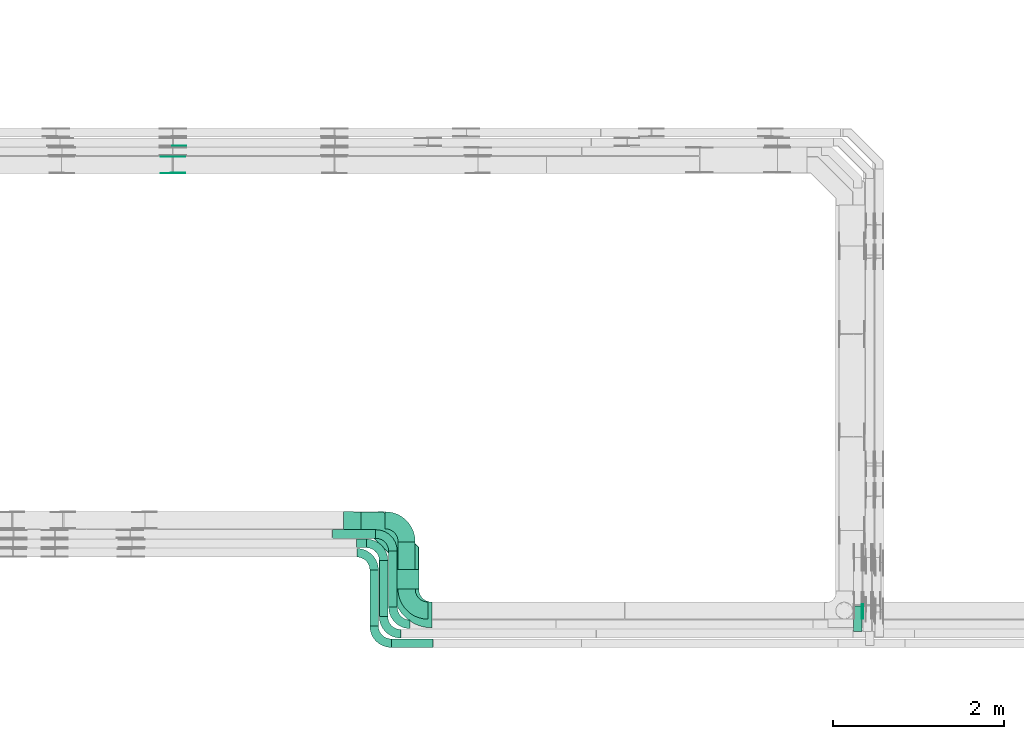
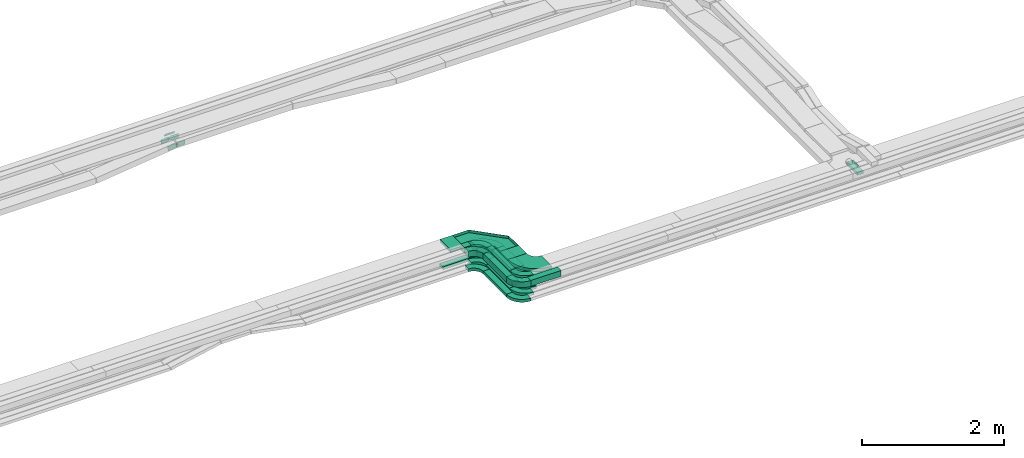
# One storey, part 22 of 32: 21 flow fittings, 12 flow segments.
"""IFC2X3 building model written with IfcOpenShell, lengths in millimetres."""

from ifc_helpers import new_model, entity, si_unit, converted_unit, derived_unit, direction, frame, frame_2d, origin, origin_2d_with_axis, place, context, subcontext, project, spatial, polyline, circle_curve, parameter, trimmed, segment, composite_curve, rectangle, outline, extrude, faceted_brep, source, transform, mapped, material, type_object, type_shapes, element, save


model = new_model("IFC2X3")

# Units and contexts
model_context = context("Model", 3, precision=0.01, world=origin(), true_north=direction((6.12303176911189e-17, 1.0)))
body_context = subcontext(model_context, "Body", "Model", "MODEL_VIEW")
ifc_project = project(units=[si_unit("LENGTHUNIT", "METRE", prefix="MILLI"), si_unit("AREAUNIT", "SQUARE_METRE"), si_unit("VOLUMEUNIT", "CUBIC_METRE"), converted_unit("PLANEANGLEUNIT", "DEGREE", entity("IfcRatioMeasure", 0.0174532925199433), si_unit("PLANEANGLEUNIT", "RADIAN"), dimensions=[0, 0, 0, 0, 0, 0, 0]), si_unit("MASSUNIT", "GRAM", prefix="KILO"), derived_unit("MASSDENSITYUNIT", [(si_unit("MASSUNIT", "GRAM", prefix="KILO"), 1), (si_unit("LENGTHUNIT", "METRE"), -3)]), derived_unit("MOMENTOFINERTIAUNIT", [(si_unit("LENGTHUNIT", "METRE"), 4)]), si_unit("TIMEUNIT", "SECOND"), si_unit("FREQUENCYUNIT", "HERTZ"), si_unit("THERMODYNAMICTEMPERATUREUNIT", "DEGREE_CELSIUS"), derived_unit("THERMALTRANSMITTANCEUNIT", [(si_unit("MASSUNIT", "GRAM", prefix="KILO"), 1), (si_unit("THERMODYNAMICTEMPERATUREUNIT", "KELVIN"), -1), (si_unit("TIMEUNIT", "SECOND"), -3)]), derived_unit("VOLUMETRICFLOWRATEUNIT", [(si_unit("LENGTHUNIT", "METRE"), 3), (si_unit("TIMEUNIT", "SECOND"), -1)]), derived_unit("MASSFLOWRATEUNIT", [(si_unit("MASSUNIT", "GRAM", prefix="KILO"), 1), (si_unit("TIMEUNIT", "SECOND"), -1)]), derived_unit("ROTATIONALFREQUENCYUNIT", [(si_unit("TIMEUNIT", "SECOND"), -1)]), si_unit("ELECTRICCURRENTUNIT", "AMPERE"), si_unit("ELECTRICVOLTAGEUNIT", "VOLT"), si_unit("POWERUNIT", "WATT"), si_unit("FORCEUNIT", "NEWTON", prefix="KILO"), si_unit("ILLUMINANCEUNIT", "LUX"), si_unit("LUMINOUSFLUXUNIT", "LUMEN"), si_unit("LUMINOUSINTENSITYUNIT", "CANDELA"), derived_unit("USERDEFINED", [(si_unit("MASSUNIT", "GRAM", prefix="KILO"), -1), (si_unit("LENGTHUNIT", "METRE"), -2), (si_unit("TIMEUNIT", "SECOND"), 3), (si_unit("LUMINOUSFLUXUNIT", "LUMEN"), 1)]), derived_unit("LINEARVELOCITYUNIT", [(si_unit("LENGTHUNIT", "METRE"), 1), (si_unit("TIMEUNIT", "SECOND"), -1)]), si_unit("PRESSUREUNIT", "PASCAL"), derived_unit("USERDEFINED", [(si_unit("LENGTHUNIT", "METRE"), -2), (si_unit("MASSUNIT", "GRAM", prefix="KILO"), 1), (si_unit("TIMEUNIT", "SECOND"), -2)]), derived_unit("LINEARFORCEUNIT", [(si_unit("MASSUNIT", "GRAM", prefix="KILO"), 1), (si_unit("LENGTHUNIT", "METRE"), 1), (si_unit("TIMEUNIT", "SECOND"), -2), (si_unit("LENGTHUNIT", "METRE"), -1)]), derived_unit("PLANARFORCEUNIT", [(si_unit("MASSUNIT", "GRAM", prefix="KILO"), 1), (si_unit("LENGTHUNIT", "METRE"), 1), (si_unit("TIMEUNIT", "SECOND"), -2), (si_unit("LENGTHUNIT", "METRE"), -2)])], contexts=[model_context])

# Site, building, storey
site_placement = place(None, origin())
site = spatial("IfcSite", under=ifc_project, at=site_placement, CompositionType="ELEMENT")
building_placement = place(site_placement, origin())
building = spatial("IfcBuilding", under=site, at=building_placement, CompositionType="ELEMENT")
storey_placement = place(building_placement, frame((0.0, 0.0, 8100.0)))
storey = spatial("IfcBuildingStorey", under=building, at=storey_placement, CompositionType="ELEMENT", Elevation=8100.0)

# Flow segments
cable_carrier_segment_type = type_object("IfcCableCarrierSegmentType", PredefinedType="CABLETRAYSEGMENT")
flow_segment_1_placement = place(storey_placement, frame((55150.11, 9320.98, 2549.84)))
element("IfcFlowSegment", 1, at=flow_segment_1_placement, inside=storey, type_object=cable_carrier_segment_type, context=body_context, shape_type="SweptSolid", body=[
    extrude(rectangle(XDim=553.020769727205, YDim=200.000000000007, at=origin_2d_with_axis()), frame((100.0, 276.51, 0.0), z_axis=(0.0, 0.0, 1.0), x_axis=(0.0, 1.0, 0.0)), (0.0, 0.0, 1.0), 99.9999999999989),
])
flow_segment_2_placement = place(storey_placement, frame((55040.11, 9110.98, 2549.87)))
element("IfcFlowSegment", 2, at=flow_segment_2_placement, inside=storey, type_object=cable_carrier_segment_type, context=body_context, shape_type="SweptSolid", body=[
    extrude(rectangle(XDim=653.020769727202, YDim=99.9999999999946, at=origin_2d_with_axis()), frame((50.0, 326.51, 0.0), z_axis=(0.0, 0.0, 1.0), x_axis=(0.0, 1.0, 0.0)), (0.0, 0.0, 1.0), 50.0000000000016),
])
flow_segment_3_placement = place(storey_placement, frame((54930.11, 9000.98, 2549.87)))
element("IfcFlowSegment", 3, at=flow_segment_3_placement, inside=storey, type_object=cable_carrier_segment_type, context=body_context, shape_type="SweptSolid", body=[
    extrude(rectangle(XDim=653.020769727214, YDim=99.9999999999946, at=origin_2d_with_axis()), frame((50.0, 326.51, 0.0), z_axis=(0.0, 0.0, 1.0), x_axis=(0.0, 1.0, 0.0)), (0.0, 0.0, 1.0), 50.0000000000016),
])
flow_segment_4_placement = place(storey_placement, frame((54820.11, 8890.98, 2548.16)))
element("IfcFlowSegment", 4, at=flow_segment_4_placement, inside=storey, type_object=cable_carrier_segment_type, context=body_context, shape_type="SweptSolid", body=[
    extrude(rectangle(XDim=653.019323064651, YDim=99.9999999999946, at=origin_2d_with_axis()), frame((50.0, 326.51, 0.0), z_axis=(0.0, 0.0, 1.0), x_axis=(0.0, 1.0, 0.0)), (0.0, 0.0, 1.0), 50.0000000000016),
])
flow_segment_5_placement = place(storey_placement, frame((55092.34, 9320.54, 2789.1)))
element("IfcFlowSegment", 5, at=flow_segment_5_placement, inside=storey, type_object=cable_carrier_segment_type, context=body_context, shape_type="SweptSolid", body=[
    extrude(rectangle(XDim=228.305561513048, YDim=299.999999999992, at=origin_2d_with_axis()), frame((150.11, 114.33, 0.07), z_axis=(5.78252488002628e-07, -0.0006102790268846, 0.99999981377957), x_axis=(-0.000947520880238993, 0.999999364881477, 0.000610279300837866)), (0.0, 0.0, 1.0), 50.0000000000009),
])
flow_segment_6_placement = place(storey_placement, frame((54930.33, 9000.97, 2799.84)))
element("IfcFlowSegment", 6, at=flow_segment_6_placement, inside=storey, type_object=cable_carrier_segment_type, context=body_context, shape_type="SweptSolid", body=[
    extrude(rectangle(XDim=653.020791015254, YDim=99.9999999999946, at=origin_2d_with_axis()), frame((50.0, 326.51, 0.07), z_axis=(0.0, 0.000204778842239003, 0.999999979032813), x_axis=(0.0, -0.999999979032813, 0.000204778842239003)), (0.0, 0.0, 1.0), 100.000000000001),
])
flow_segment_7_placement = place(storey_placement, frame((54820.11, 8890.97, 2799.32)))
element("IfcFlowSegment", 7, at=flow_segment_7_placement, inside=storey, type_object=cable_carrier_segment_type, context=body_context, shape_type="SweptSolid", body=[
    extrude(rectangle(XDim=653.022106435861, YDim=99.999999999999, at=origin_2d_with_axis()), frame((50.0, 326.51, 0.07), z_axis=(8.83740140805357e-07, 0.000204835246373141, 0.99999997902087), x_axis=(0.0, -0.999999979021261, 0.000204835246373221)), (0.0, 0.0, 1.0), 99.9999999999998),
])
flow_segment_8_placement = place(storey_placement, frame((55071.11, 8639.98, 2799.49)))
element("IfcFlowSegment", 8, at=flow_segment_8_placement, inside=storey, type_object=cable_carrier_segment_type, context=body_context, shape_type="SweptSolid", body=[
    extrude(rectangle(XDim=489.621580336119, YDim=99.9999999999995, at=origin_2d_with_axis()), frame((244.81, 50.0, 0.0), z_axis=(3.16498725628962e-07, -2.43771475119288e-05, 1.0), x_axis=(-1.0, 0.0, 3.16498724808628e-07)), (0.0, 0.0, 1.0), 99.999999999998),
])
flow_segment_9_placement = place(storey_placement, frame((54382.06, 9915.0, 2549.87)))
element("IfcFlowSegment", 9, at=flow_segment_9_placement, inside=storey, type_object=cable_carrier_segment_type, context=body_context, shape_type="SweptSolid", body=[
    extrude(rectangle(XDim=507.047725147146, YDim=99.9999999999989, at=origin_2d_with_axis()), frame((253.52, 50.0, 0.0)), (0.0, 0.0, 1.0), 50.0000000000016),
])
flow_segment_10_placement = place(storey_placement, frame((54664.86, 9805.0, 2799.81)))
element("IfcFlowSegment", 10, at=flow_segment_10_placement, inside=storey, type_object=cable_carrier_segment_type, context=body_context, shape_type="SweptSolid", body=[
    extrude(rectangle(XDim=114.4721271414, YDim=99.9999999999989, at=origin_2d_with_axis()), frame((57.24, 50.0, 0.0)), (0.0, 0.0, 1.0), 99.9999999999998),
])
flow_segment_11_placement = place(storey_placement, frame((60470.11, 8826.03, 2697.68)))
element("IfcFlowSegment", 11, at=flow_segment_11_placement, inside=storey, type_object=cable_carrier_segment_type, context=body_context, shape_type="SweptSolid", body=[
    extrude(rectangle(XDim=300.444409805727, YDim=99.9999999999946, at=origin_2d_with_axis()), frame((50.0, 150.22, 0.0), z_axis=(0.0, 0.0, 1.0), x_axis=(0.0, -1.0, 0.0)), (0.0, 0.0, 1.0), 50.0000000000016),
])
flow_segment_12_placement = place(storey_placement, frame((54509.61, 9924.5, 2789.68)))
element("IfcFlowSegment", 12, at=flow_segment_12_placement, inside=storey, type_object=cable_carrier_segment_type, context=body_context, shape_type="SweptSolid", body=[
    extrude(rectangle(XDim=205.870314110573, YDim=299.999999999673, at=origin_2d_with_axis()), frame((103.3, 150.25, 0.02), z_axis=(0.000218923897814859, -3.57656509615694e-09, 0.999999976036163), x_axis=(0.999997044780487, -0.0024212606005856, -0.000218923264752722)), (0.0, 0.0, 1.0), 49.9999999999447),
])

# Flow fittings
ifc_material_1 = material()
cable_carrier_fitting_type_1 = type_object("IfcCableCarrierFittingType", Name="470_DKC_G5_Sheet horizontal bend:-", PredefinedType="NOTDEFINED", material=ifc_material_1)
shared_shape_1 = source(origin(), body_context, "Body", "Brep", [
    faceted_brep([(-526.0, -150.0, -25.0), (-526.0, -150.0, 25.0), (-526.0, -145.0, 25.0), (-526.0, -145.0, -20.0), (-526.0, 145.0, -20.0), (-526.0, 145.0, 25.0), (-526.0, 150.0, 25.0), (-526.0, 150.0, -25.0), (150.0, 526.0, -25.0), (-150.0, 526.0, -25.0), (-150.0, 526.0, 25.0), (-145.0, 526.0, 25.0), (-145.0, 526.0, -20.0), (145.0, 526.0, -20.0), (145.0, 526.0, 25.0), (150.0, 526.0, 25.0), (-262.87, -150.0, -25.0), (-262.87, -150.0, 25.0), (150.0, 262.87, 25.0), (145.0, 264.94, 25.0), (-264.94, -145.0, 25.0), (-264.94, -145.0, -20.0), (145.0, 264.94, -20.0), (-145.0, 385.06, -20.0), (-385.06, 145.0, -20.0), (-385.06, 145.0, 25.0), (-145.0, 385.06, 25.0), (-150.0, 387.13, 25.0), (-387.13, 150.0, 25.0), (-387.13, 150.0, -25.0), (-150.0, 387.13, -25.0), (150.0, 262.87, -25.0)], [[[0, 1, 2, 3, 4, 5, 6, 7]], [[8, 9, 10, 11, 12, 13, 14, 15]], [[1, 0, 16, 17]], [[2, 1, 17, 18, 15, 14, 19, 20]], [[3, 2, 20, 21]], [[4, 3, 21, 22, 13, 12, 23, 24]], [[5, 4, 24, 25]], [[6, 5, 25, 26, 11, 10, 27, 28]], [[7, 6, 28, 29]], [[0, 7, 29, 30, 9, 8, 31, 16]], [[17, 16, 31, 18]], [[21, 20, 19, 22]], [[25, 24, 23, 26]], [[29, 28, 27, 30]], [[18, 31, 8, 15]], [[22, 19, 14, 13]], [[26, 23, 12, 11]], [[30, 27, 10, 9]]]),
])
type_shapes(cable_carrier_fitting_type_1, [shared_shape_1])
flow_fitting_1_placement = place(storey_placement, frame((55241.84, 10075.0, 2814.56), z_axis=(0.000217446714460899, -0.000610073525006781, 0.999999790263588), x_axis=(-0.000947520880238993, 0.999999364881477, 0.000610279300837866)))
element("IfcFlowFitting", 13, at=flow_fitting_1_placement, inside=storey, type_object=cable_carrier_fitting_type_1, material=ifc_material_1, Name="470_DKC_G5_Sheet horizontal bend:-", ObjectType="470_DKC_G5_Sheet horizontal bend:-", context=body_context, shape_type="MappedRepresentation", body=[
    mapped(shared_shape_1, transform((0.0, 0.0, 0.0), scale=1.0)),
])
cable_carrier_fitting_type_2 = type_object("IfcCableCarrierFittingType", Name="470_DKC_S5_Variable Angle Elbow 0-45:-", PredefinedType="NOTDEFINED", material=ifc_material_1)
shared_shape_2 = source(origin(), body_context, "Body", "SweptSolid", [
    extrude(outline(composite_curve([segment(polyline([(-125.75, -225.25), (-124.75, -225.25)]), True, "CONTINUOUS"), segment(trimmed(circle_curve(frame_2d((-124.75, 124.75), x_axis=(0.0, -1.0)), 350.0), [parameter(0.0)], [parameter(90.0000000000001)], True, "PARAMETER"), True, "CONTINUOUS"), segment(polyline([(225.25, 124.75), (225.25, 125.75)]), True, "CONTINUOUS"), segment(polyline([(225.25, 125.75), (25.25, 125.75)]), True, "CONTINUOUS"), segment(polyline([(25.25, 125.75), (25.25, 124.75)]), True, "CONTINUOUS"), segment(trimmed(circle_curve(frame_2d((-124.75, 124.75), x_axis=(0.0, -1.0)), 150.0), [parameter(0.0)], [parameter(90.0000000000001)], True, "PARAMETER"), False, "CONTINUOUS"), segment(polyline([(-124.75, -25.25), (-125.75, -25.25)]), True, "CONTINUOUS"), segment(polyline([(-125.75, -25.25), (-125.75, -225.25)]), True, "CONTINUOUS")], self_intersect=False)), frame((-125.25, 125.25, -50.0)), (0.0, 0.0, 1.0), 100.0),
])
type_shapes(cable_carrier_fitting_type_2, [shared_shape_2])
flow_fitting_2_placement = place(storey_placement, frame((55250.11, 9069.98, 2599.84), z_axis=(0.0, 0.0, 1.0), x_axis=(0.0, -1.0, 0.0)))
element("IfcFlowFitting", 14, at=flow_fitting_2_placement, inside=storey, type_object=cable_carrier_fitting_type_2, material=ifc_material_1, Name="470_DKC_S5_Variable Angle Elbow 0-45:-", ObjectType="470_DKC_S5_Variable Angle Elbow 0-45:-", context=body_context, shape_type="MappedRepresentation", body=[
    mapped(shared_shape_2, transform((0.0, 0.0, 0.0), scale=1.0)),
])
cable_carrier_fitting_type_3 = type_object("IfcCableCarrierFittingType", Name="470_DKC_S5_Variable Angle Elbow 0-45:-", PredefinedType="NOTDEFINED", material=ifc_material_1)
type_shapes(cable_carrier_fitting_type_3, [shared_shape_2])
flow_fitting_3_placement = place(storey_placement, frame((55250.11, 10125.0, 2599.84), z_axis=(6.39848897038753e-05, 0.0, 0.999999997952967), x_axis=(0.0, 1.0, 0.0)))
element("IfcFlowFitting", 15, at=flow_fitting_3_placement, inside=storey, type_object=cable_carrier_fitting_type_3, material=ifc_material_1, Name="470_DKC_S5_Variable Angle Elbow 0-45:-", ObjectType="470_DKC_S5_Variable Angle Elbow 0-45:-", context=body_context, shape_type="MappedRepresentation", body=[
    mapped(shared_shape_2, transform((0.0, 0.0, 0.0), scale=1.0)),
])
cable_carrier_fitting_type_4 = type_object("IfcCableCarrierFittingType", Name="470_DKC_S5_Variable Angle Elbow 0-45:-", PredefinedType="NOTDEFINED", material=ifc_material_1)
shared_shape_3 = source(origin(), body_context, "Body", "SweptSolid", [
    extrude(outline(composite_curve([segment(polyline([(-100.75, -150.25), (-99.75, -150.25)]), True, "CONTINUOUS"), segment(trimmed(circle_curve(frame_2d((-99.75, 99.75), x_axis=(0.0, -1.0)), 250.0), [parameter(0.0)], [parameter(90.0000000000001)], True, "PARAMETER"), True, "CONTINUOUS"), segment(polyline([(150.25, 99.75), (150.25, 100.75)]), True, "CONTINUOUS"), segment(polyline([(150.25, 100.75), (50.25, 100.75)]), True, "CONTINUOUS"), segment(polyline([(50.25, 100.75), (50.25, 99.75)]), True, "CONTINUOUS"), segment(trimmed(circle_curve(frame_2d((-99.75, 99.75), x_axis=(0.0, -1.0)), 150.0), [parameter(0.0)], [parameter(90.0000000000001)], True, "PARAMETER"), False, "CONTINUOUS"), segment(polyline([(-99.75, -50.25), (-100.75, -50.25)]), True, "CONTINUOUS"), segment(polyline([(-100.75, -50.25), (-100.75, -150.25)]), True, "CONTINUOUS")], self_intersect=False)), frame((-100.25, 100.25, -25.0)), (0.0, 0.0, 1.0), 49.9999999999997),
])
type_shapes(cable_carrier_fitting_type_4, [shared_shape_3])
for number, where, z_axis, x_axis, name in (
    (16, (55090.11, 8909.98, 2574.87), (0.0, 0.0, 1.0), (0.0, -1.0, 0.0), "470_DKC_S5_Variable Angle Elbow 0-45:-"),
    (17, (54980.11, 8799.98, 2574.87), (0.0, 0.0, 1.0), (0.0, -1.0, 0.0), "470_DKC_S5_Variable Angle Elbow 0-45:-"),
    (18, (54870.11, 8689.98, 2573.16), (0.0, 0.0, 1.0), (0.0, -1.0, 0.0), "470_DKC_S5_Variable Angle Elbow 0-45:-"),
    (19, (55090.11, 9965.0, 2574.87), (0.0, 0.0, 1.0), (0.0, 1.0, 0.0), "470_DKC_S5_Variable Angle Elbow 0-45:-"),
):
    element("IfcFlowFitting", number, at=place(storey_placement, frame(where, z_axis=z_axis, x_axis=x_axis)), inside=storey, type_object=cable_carrier_fitting_type_4, material=ifc_material_1, Name=name, ObjectType="470_DKC_S5_Variable Angle Elbow 0-45:-", context=body_context, shape_type="MappedRepresentation", body=[
        mapped(shared_shape_3, transform((0.0, 0.0, 0.0), scale=1.0)),
    ])
cable_carrier_fitting_type_5 = type_object("IfcCableCarrierFittingType", Name="470_DKC_S5_Variable Angle Elbow 0-45:-", PredefinedType="NOTDEFINED", material=ifc_material_1)
type_shapes(cable_carrier_fitting_type_5, [shared_shape_3])
for number, where, z_axis, x_axis, name in (
    (20, (54980.11, 9855.0, 2574.87), (5.61945698180408e-05, 0.0, 1.0), (0.0, 1.0, 0.0), "470_DKC_S5_Variable Angle Elbow 0-45:-"),
    (21, (54870.11, 9745.0, 2573.16), (5.86021096764089e-05, 0.0, 1.0), (0.0, 1.0, 0.0), "470_DKC_S5_Variable Angle Elbow 0-45:-"),
):
    element("IfcFlowFitting", number, at=place(storey_placement, frame(where, z_axis=z_axis, x_axis=x_axis)), inside=storey, type_object=cable_carrier_fitting_type_5, material=ifc_material_1, Name=name, ObjectType="470_DKC_S5_Variable Angle Elbow 0-45:-", context=body_context, shape_type="MappedRepresentation", body=[
        mapped(shared_shape_3, transform((0.0, 0.0, 0.0), scale=1.0)),
    ])
ifc_material_2 = material(Name="G")
cable_carrier_fitting_type_6 = type_object("IfcCableCarrierFittingType", PredefinedType="NOTDEFINED", material=ifc_material_2)
shared_shape_4 = source(origin(), body_context, "Body", "SweptSolid", [
    extrude(outline(composite_curve([segment(trimmed(circle_curve(frame_2d((-44.59, 0.0), x_axis=(1.0, 0.0)), 12.5), [parameter(90.0000000000007)], [parameter(270.0)], True, "PARAMETER"), True, "CONTINUOUS"), segment(polyline([(-44.59, -12.5), (-33.09, -12.5)]), True, "CONTINUOUS"), segment(polyline([(-33.09, -12.5), (-31.23, -14.5)]), True, "CONTINUOUS"), segment(polyline([(-31.23, -14.5), (108.91, -14.5)]), True, "CONTINUOUS"), segment(polyline([(108.91, -14.5), (108.91, 14.5)]), True, "CONTINUOUS"), segment(polyline([(108.91, 14.5), (-31.23, 14.5)]), True, "CONTINUOUS"), segment(polyline([(-31.23, 14.5), (-33.09, 12.5)]), True, "CONTINUOUS"), segment(polyline([(-33.09, 12.5), (-44.59, 12.5)]), True, "CONTINUOUS")], self_intersect=False)), frame((44.59, 0.0, 0.0), z_axis=(0.0, 0.0, -1.0), x_axis=(1.0, 0.0, 0.0)), (0.0, 0.0, -1.0), 2.0),
])
type_shapes(cable_carrier_fitting_type_6, [shared_shape_4])
flow_fitting_4_placement = place(storey_placement, frame((60565.57, 9131.25, 2722.68), z_axis=(1.0, 0.0, 0.0), x_axis=(0.0, -1.0, 0.0)))
element("IfcFlowFitting", 22, at=flow_fitting_4_placement, inside=storey, type_object=cable_carrier_fitting_type_6, material=ifc_material_2, context=body_context, shape_type="MappedRepresentation", body=[
    mapped(shared_shape_4, transform((0.0, 0.0, 0.0), scale=1.0)),
])
cable_carrier_fitting_type_7 = type_object("IfcCableCarrierFittingType", PredefinedType="NOTDEFINED", material=ifc_material_2)
shared_shape_5 = source(origin(), body_context, "Body", "SweptSolid", [
    extrude(outline(composite_curve([segment(trimmed(circle_curve(frame_2d((-44.59, 0.0), x_axis=(1.0, 0.0)), 12.5), [parameter(90.0000000000007)], [parameter(270.0)], True, "PARAMETER"), True, "CONTINUOUS"), segment(polyline([(-44.59, -12.5), (-33.09, -12.5)]), True, "CONTINUOUS"), segment(polyline([(-33.09, -12.5), (-31.23, -14.5)]), True, "CONTINUOUS"), segment(polyline([(-31.23, -14.5), (108.91, -14.5)]), True, "CONTINUOUS"), segment(polyline([(108.91, -14.5), (108.91, 14.5)]), True, "CONTINUOUS"), segment(polyline([(108.91, 14.5), (-31.23, 14.5)]), True, "CONTINUOUS"), segment(polyline([(-31.23, 14.5), (-33.09, 12.5)]), True, "CONTINUOUS"), segment(polyline([(-33.09, 12.5), (-44.59, 12.5)]), True, "CONTINUOUS")], self_intersect=False)), frame((44.59, 0.0, 0.0)), (0.0, 0.0, 1.0), 2.0),
])
type_shapes(cable_carrier_fitting_type_7, [shared_shape_5])
flow_fitting_5_placement = place(storey_placement, frame((60584.65, 9131.25, 2722.68), z_axis=(-1.0, 0.0, 0.0), x_axis=(0.0, -1.0, 0.0)))
element("IfcFlowFitting", 23, at=flow_fitting_5_placement, inside=storey, type_object=cable_carrier_fitting_type_7, material=ifc_material_2, context=body_context, shape_type="MappedRepresentation", body=[
    mapped(shared_shape_5, transform((0.0, 0.0, 0.0), scale=1.0)),
])
cable_carrier_fitting_type_8 = type_object("IfcCableCarrierFittingType", PredefinedType="NOTDEFINED", material=ifc_material_2)
type_shapes(cable_carrier_fitting_type_8, [shared_shape_5])
flow_fitting_6_placement = place(storey_placement, frame((52522.91, 14498.82, 2729.02), z_axis=(0.0, -1.0, 0.0), x_axis=(1.0, 0.0, 0.0)))
element("IfcFlowFitting", 24, at=flow_fitting_6_placement, inside=storey, type_object=cable_carrier_fitting_type_8, material=ifc_material_2, context=body_context, shape_type="MappedRepresentation", body=[
    mapped(shared_shape_5, transform((0.0, 0.0, 0.0), scale=1.0)),
])
cable_carrier_fitting_type_9 = type_object("IfcCableCarrierFittingType", Name="470_DKC_S5_Variable Angle Elbow 0-45:-", PredefinedType="NOTDEFINED", material=ifc_material_1)
shared_shape_6 = source(origin(), body_context, "Body", "SweptSolid", [
    extrude(outline(composite_curve([segment(polyline([(-100.75, -150.25), (-99.75, -150.25)]), True, "CONTINUOUS"), segment(trimmed(circle_curve(frame_2d((-99.75, 99.75), x_axis=(0.0, -1.0)), 250.0), [parameter(0.0)], [parameter(90.0000000000001)], True, "PARAMETER"), True, "CONTINUOUS"), segment(polyline([(150.25, 99.75), (150.25, 100.75)]), True, "CONTINUOUS"), segment(polyline([(150.25, 100.75), (50.25, 100.75)]), True, "CONTINUOUS"), segment(polyline([(50.25, 100.75), (50.25, 99.75)]), True, "CONTINUOUS"), segment(trimmed(circle_curve(frame_2d((-99.75, 99.75), x_axis=(0.0, -1.0)), 150.0), [parameter(0.0)], [parameter(90.0000000000001)], True, "PARAMETER"), False, "CONTINUOUS"), segment(polyline([(-99.75, -50.25), (-100.75, -50.25)]), True, "CONTINUOUS"), segment(polyline([(-100.75, -50.25), (-100.75, -150.25)]), True, "CONTINUOUS")], self_intersect=False)), frame((-100.25, 100.25, -50.0)), (0.0, 0.0, 1.0), 100.0),
])
type_shapes(cable_carrier_fitting_type_9, [shared_shape_6])
for number, where, z_axis, x_axis, name in (
    (25, (54870.11, 9745.0, 2849.28), (4.69987059929388e-07, 0.000204835246372701, 0.99999997902115), (0.0, 0.999999979021261, -0.000204835246372724), "470_DKC_S5_Variable Angle Elbow 0-45:-"),
    (26, (54870.11, 8689.98, 2849.49), (3.16498718168883e-07, 0.00020483524637321, 0.999999979021211), (0.0, -0.999999979021261, 0.000204835246373221), "470_DKC_S5_Variable Angle Elbow 0-45:-"),
    (27, (54980.33, 8799.98, 2850.02), (8.83740159515312e-07, 0.000204778842238923, 0.999999979032422), (0.0, -0.999999979032813, 0.000204778842239003), "470_DKC_S5_Variable Angle Elbow 0-45:-"),
):
    element("IfcFlowFitting", number, at=place(storey_placement, frame(where, z_axis=z_axis, x_axis=x_axis)), inside=storey, type_object=cable_carrier_fitting_type_9, material=ifc_material_1, Name=name, ObjectType="470_DKC_S5_Variable Angle Elbow 0-45:-", context=body_context, shape_type="MappedRepresentation", body=[
        mapped(shared_shape_6, transform((0.0, 0.0, 0.0), scale=1.0)),
    ])
cable_carrier_fitting_type_10 = type_object("IfcCableCarrierFittingType", PredefinedType="NOTDEFINED", material=ifc_material_2)
shared_shape_7 = source(origin(), body_context, "Body", "SweptSolid", [
    extrude(outline(composite_curve([segment(trimmed(circle_curve(frame_2d((-41.47, 0.0), x_axis=(1.0, 0.0)), 25.0), [parameter(90.0000000000007)], [parameter(270.0)], True, "PARAMETER"), True, "CONTINUOUS"), segment(polyline([(-41.47, -25.0), (-29.97, -25.0)]), True, "CONTINUOUS"), segment(polyline([(-29.97, -25.0), (-28.1, -38.5)]), True, "CONTINUOUS"), segment(polyline([(-28.1, -38.5), (99.53, -38.5)]), True, "CONTINUOUS"), segment(polyline([(99.53, -38.5), (99.53, 38.5)]), True, "CONTINUOUS"), segment(polyline([(99.53, 38.5), (-28.1, 38.5)]), True, "CONTINUOUS"), segment(polyline([(-28.1, 38.5), (-29.97, 25.0)]), True, "CONTINUOUS"), segment(polyline([(-29.97, 25.0), (-41.47, 25.0)]), True, "CONTINUOUS")], self_intersect=False)), frame((41.47, 0.0, 0.0), z_axis=(0.0, 0.0, -1.0), x_axis=(1.0, 0.0, 0.0)), (0.0, 0.0, -1.0), 2.0),
])
type_shapes(cable_carrier_fitting_type_10, [shared_shape_7])
flow_fitting_7_placement = place(storey_placement, frame((52520.91, 14179.04, 2754.58), z_axis=(0.0, -1.0, 0.0), x_axis=(-0.992897734535631, 0.0, -0.118970957607356)))
element("IfcFlowFitting", 28, at=flow_fitting_7_placement, inside=storey, type_object=cable_carrier_fitting_type_10, material=ifc_material_2, context=body_context, shape_type="MappedRepresentation", body=[
    mapped(shared_shape_7, transform((0.0, 0.0, 0.0), scale=1.0)),
])
cable_carrier_fitting_type_11 = type_object("IfcCableCarrierFittingType", PredefinedType="NOTDEFINED", material=ifc_material_2)
type_shapes(cable_carrier_fitting_type_11, [shared_shape_7])
flow_fitting_8_placement = place(storey_placement, frame((52520.91, 14367.96, 2754.58), z_axis=(0.0, 1.0, 0.0), x_axis=(1.0, 0.0, 0.0)))
element("IfcFlowFitting", 29, at=flow_fitting_8_placement, inside=storey, type_object=cable_carrier_fitting_type_11, material=ifc_material_2, context=body_context, shape_type="MappedRepresentation", body=[
    mapped(shared_shape_7, transform((0.0, 0.0, 0.0), scale=1.0)),
])
cable_carrier_fitting_type_12 = type_object("IfcCableCarrierFittingType", PredefinedType="NOTDEFINED", material=ifc_material_2)
shared_shape_8 = source(origin(), body_context, "Body", "SweptSolid", [
    extrude(outline(composite_curve([segment(trimmed(circle_curve(frame_2d((-41.47, 0.0), x_axis=(1.0, 0.0)), 25.0), [parameter(90.0000000000007)], [parameter(270.0)], True, "PARAMETER"), True, "CONTINUOUS"), segment(polyline([(-41.47, -25.0), (-29.97, -25.0)]), True, "CONTINUOUS"), segment(polyline([(-29.97, -25.0), (-28.1, -38.5)]), True, "CONTINUOUS"), segment(polyline([(-28.1, -38.5), (99.53, -38.5)]), True, "CONTINUOUS"), segment(polyline([(99.53, -38.5), (99.53, 38.5)]), True, "CONTINUOUS"), segment(polyline([(99.53, 38.5), (-28.1, 38.5)]), True, "CONTINUOUS"), segment(polyline([(-28.1, 38.5), (-29.97, 25.0)]), True, "CONTINUOUS"), segment(polyline([(-29.97, 25.0), (-41.47, 25.0)]), True, "CONTINUOUS")], self_intersect=False)), frame((41.47, 0.0, 0.0)), (0.0, 0.0, 1.0), 2.0),
])
type_shapes(cable_carrier_fitting_type_12, [shared_shape_8])
flow_fitting_9_placement = place(storey_placement, frame((52520.91, 14369.96, 2754.58), z_axis=(0.0, 1.0, 0.0), x_axis=(-0.992897734535631, 0.0, -0.118970957607356)))
element("IfcFlowFitting", 30, at=flow_fitting_9_placement, inside=storey, type_object=cable_carrier_fitting_type_12, material=ifc_material_2, context=body_context, shape_type="MappedRepresentation", body=[
    mapped(shared_shape_8, transform((0.0, 0.0, 0.0), scale=1.0)),
])
cable_carrier_fitting_type_13 = type_object("IfcCableCarrierFittingType", PredefinedType="NOTDEFINED", material=ifc_material_2)
type_shapes(cable_carrier_fitting_type_13, [shared_shape_8])
flow_fitting_10_placement = place(storey_placement, frame((52520.91, 14181.04, 2754.58), z_axis=(0.0, -1.0, 0.0), x_axis=(1.0, 0.0, 0.0)))
element("IfcFlowFitting", 31, at=flow_fitting_10_placement, inside=storey, type_object=cable_carrier_fitting_type_13, material=ifc_material_2, context=body_context, shape_type="MappedRepresentation", body=[
    mapped(shared_shape_8, transform((0.0, 0.0, 0.0), scale=1.0)),
])
cable_carrier_fitting_type_14 = type_object("IfcCableCarrierFittingType", Name="470_DKC_S5_Variable Angle Elbow 0-45:-", PredefinedType="NOTDEFINED", material=ifc_material_1)
shared_shape_9 = source(origin(), body_context, "Body", "SweptSolid", [
    extrude(outline(composite_curve([segment(polyline([(-150.75, -300.11), (-149.75, -300.11)]), True, "CONTINUOUS"), segment(trimmed(circle_curve(frame_2d((-149.75, 149.89), x_axis=(0.0, -1.0)), 450.0), [parameter(0.0)], [parameter(89.9457110444371)], True, "PARAMETER"), True, "CONTINUOUS"), segment(polyline([(300.25, 149.47), (300.25, 150.47)]), True, "CONTINUOUS"), segment(polyline([(300.25, 150.47), (0.25, 150.75)]), True, "CONTINUOUS"), segment(polyline([(0.25, 150.75), (0.25, 149.75)]), True, "CONTINUOUS"), segment(trimmed(circle_curve(frame_2d((-149.75, 149.89), x_axis=(0.0, -1.0)), 150.0), [parameter(0.0)], [parameter(89.9457110444371)], True, "PARAMETER"), False, "CONTINUOUS"), segment(polyline([(-149.75, -0.11), (-150.75, -0.11)]), True, "CONTINUOUS"), segment(polyline([(-150.75, -0.11), (-150.75, -300.11)]), True, "CONTINUOUS")], self_intersect=False)), frame((-149.97, 150.11, -25.0)), (0.0, 0.0, 1.0), 49.9999999999974),
])
type_shapes(cable_carrier_fitting_type_14, [shared_shape_9])
flow_fitting_11_placement = place(storey_placement, frame((55242.84, 9019.98, 2813.92), z_axis=(0.0, -0.000610279574786019, 0.999999813779403), x_axis=(0.000947520880263047, -0.999999364881477, -0.000610279300832732)))
element("IfcFlowFitting", 32, at=flow_fitting_11_placement, inside=storey, type_object=cable_carrier_fitting_type_14, material=ifc_material_1, Name="470_DKC_S5_Variable Angle Elbow 0-45:-", ObjectType="470_DKC_S5_Variable Angle Elbow 0-45:-", context=body_context, shape_type="MappedRepresentation", body=[
    mapped(shared_shape_9, transform((0.0, 0.0, 0.0), scale=1.0)),
])
cable_carrier_fitting_type_15 = type_object("IfcCableCarrierFittingType", Name="470_DKC_S5_Variable Angle Elbow 0-45:-", PredefinedType="NOTDEFINED", material=ifc_material_1)
shared_shape_10 = source(origin(), body_context, "Body", "SweptSolid", [
    extrude(outline(composite_curve([segment(polyline([(-100.75, -150.25), (-99.75, -150.25)]), True, "CONTINUOUS"), segment(trimmed(circle_curve(frame_2d((-99.75, 99.75), x_axis=(0.0, -1.0)), 250.0), [parameter(0.0)], [parameter(90.0000002552843)], True, "PARAMETER"), True, "CONTINUOUS"), segment(polyline([(150.25, 99.75), (150.25, 100.75)]), True, "CONTINUOUS"), segment(polyline([(150.25, 100.75), (50.25, 100.75)]), True, "CONTINUOUS"), segment(polyline([(50.25, 100.75), (50.25, 99.75)]), True, "CONTINUOUS"), segment(trimmed(circle_curve(frame_2d((-99.75, 99.75), x_axis=(0.0, -1.0)), 150.0), [parameter(0.0)], [parameter(90.0000002552842)], True, "PARAMETER"), False, "CONTINUOUS"), segment(polyline([(-99.75, -50.25), (-100.75, -50.25)]), True, "CONTINUOUS"), segment(polyline([(-100.75, -50.25), (-100.75, -150.25)]), True, "CONTINUOUS")], self_intersect=False)), frame((-100.25, 100.25, -50.0)), (0.0, 0.0, 1.0), 100.0),
])
type_shapes(cable_carrier_fitting_type_15, [shared_shape_10])
flow_fitting_12_placement = place(storey_placement, frame((54980.33, 9855.0, 2849.8), z_axis=(2.17578584004726e-05, 0.000204778842189576, 0.99999997879611), x_axis=(0.0, 0.999999979032813, -0.000204778842238047)))
element("IfcFlowFitting", 33, at=flow_fitting_12_placement, inside=storey, type_object=cable_carrier_fitting_type_15, material=ifc_material_1, Name="470_DKC_S5_Variable Angle Elbow 0-45:-", ObjectType="470_DKC_S5_Variable Angle Elbow 0-45:-", context=body_context, shape_type="MappedRepresentation", body=[
    mapped(shared_shape_10, transform((0.0, 0.0, 0.0), scale=1.0)),
])

save(model, "model.ifc")
